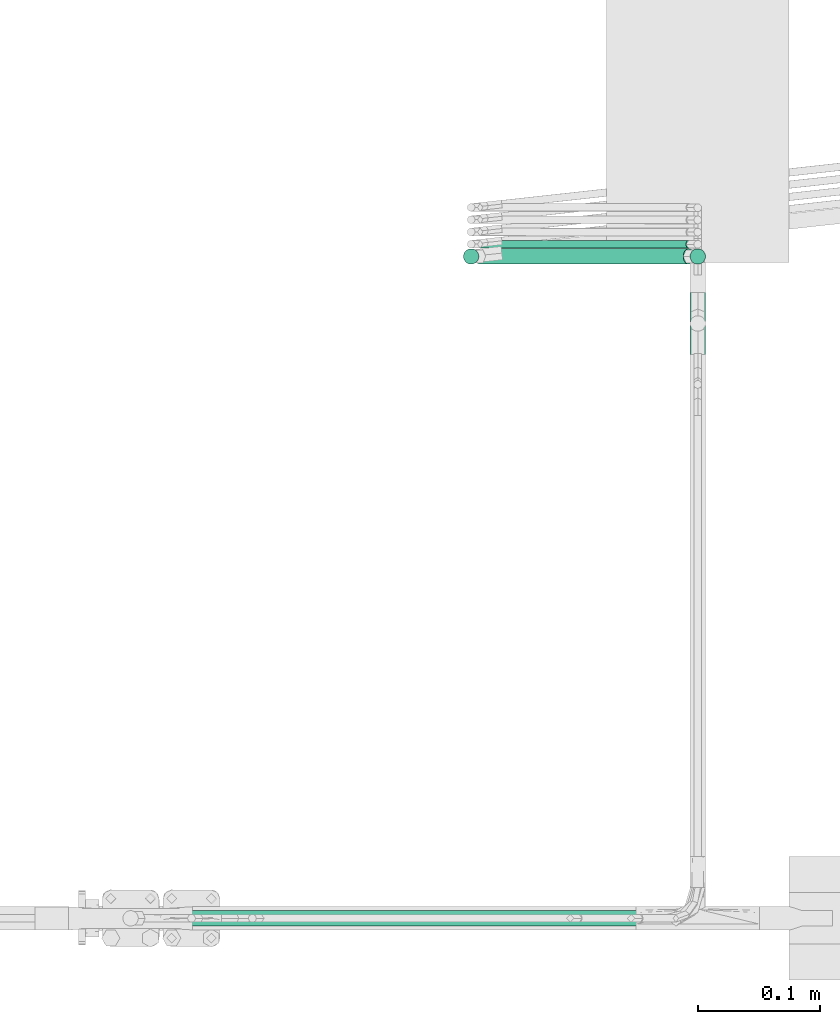
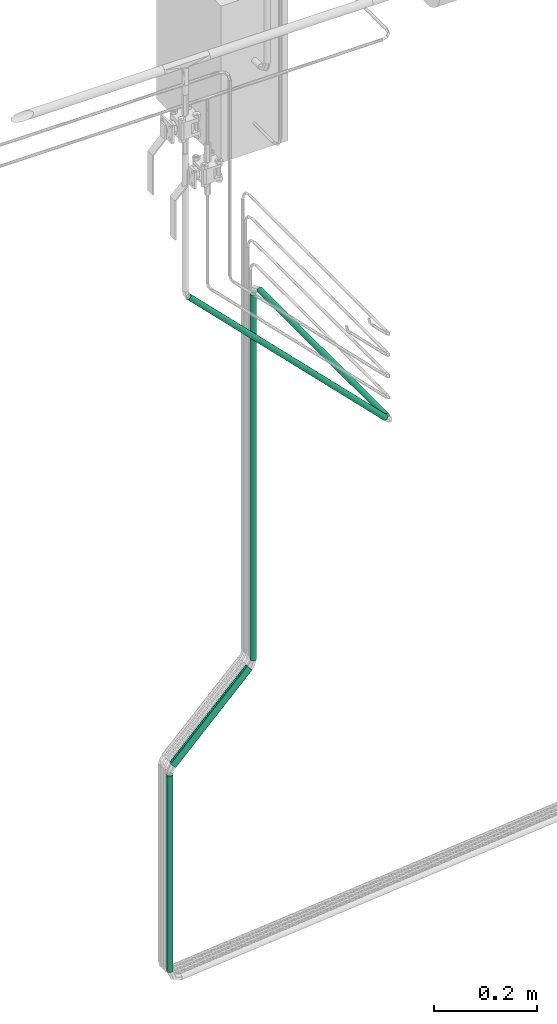
# One storey, part 10 of 45: 6 flow segments.
"""IFC2X3 building model written with IfcOpenShell, lengths in millimetres."""

from ifc_helpers import new_model, entity, si_unit, converted_unit, derived_unit, direction, frame, origin, origin_2d_with_axis, place, context, subcontext, project, spatial, circle, extrude, type_object, element, save


model = new_model("IFC2X3")

# Units and contexts
model_context = context("Model", 3, precision=0.01, world=origin(), true_north=direction((6.12303176911189e-17, 1.0)))
body_context = subcontext(model_context, "Body", "Model", "MODEL_VIEW")
ifc_project = project(units=[si_unit("LENGTHUNIT", "METRE", prefix="MILLI"), si_unit("AREAUNIT", "SQUARE_METRE"), si_unit("VOLUMEUNIT", "CUBIC_METRE"), converted_unit("PLANEANGLEUNIT", "DEGREE", entity("IfcRatioMeasure", 0.0174532925199433), si_unit("PLANEANGLEUNIT", "RADIAN"), dimensions=[0, 0, 0, 0, 0, 0, 0]), si_unit("MASSUNIT", "GRAM", prefix="KILO"), derived_unit("MASSDENSITYUNIT", [(si_unit("MASSUNIT", "GRAM", prefix="KILO"), 1), (si_unit("LENGTHUNIT", "METRE"), -3)]), derived_unit("MOMENTOFINERTIAUNIT", [(si_unit("LENGTHUNIT", "METRE"), 4)]), si_unit("TIMEUNIT", "SECOND"), si_unit("FREQUENCYUNIT", "HERTZ"), si_unit("THERMODYNAMICTEMPERATUREUNIT", "DEGREE_CELSIUS"), derived_unit("THERMALTRANSMITTANCEUNIT", [(si_unit("MASSUNIT", "GRAM", prefix="KILO"), 1), (si_unit("THERMODYNAMICTEMPERATUREUNIT", "KELVIN"), -1), (si_unit("TIMEUNIT", "SECOND"), -3)]), derived_unit("VOLUMETRICFLOWRATEUNIT", [(si_unit("LENGTHUNIT", "METRE"), 3), (si_unit("TIMEUNIT", "SECOND"), -1)]), derived_unit("MASSFLOWRATEUNIT", [(si_unit("MASSUNIT", "GRAM", prefix="KILO"), 1), (si_unit("TIMEUNIT", "SECOND"), -1)]), derived_unit("ROTATIONALFREQUENCYUNIT", [(si_unit("TIMEUNIT", "SECOND"), -1)]), si_unit("ELECTRICCURRENTUNIT", "AMPERE"), si_unit("ELECTRICVOLTAGEUNIT", "VOLT"), si_unit("POWERUNIT", "WATT"), si_unit("FORCEUNIT", "NEWTON", prefix="KILO"), si_unit("ILLUMINANCEUNIT", "LUX"), si_unit("LUMINOUSFLUXUNIT", "LUMEN"), si_unit("LUMINOUSINTENSITYUNIT", "CANDELA"), derived_unit("USERDEFINED", [(si_unit("MASSUNIT", "GRAM", prefix="KILO"), -1), (si_unit("LENGTHUNIT", "METRE"), -2), (si_unit("TIMEUNIT", "SECOND"), 3), (si_unit("LUMINOUSFLUXUNIT", "LUMEN"), 1)]), derived_unit("LINEARVELOCITYUNIT", [(si_unit("LENGTHUNIT", "METRE"), 1), (si_unit("TIMEUNIT", "SECOND"), -1)]), si_unit("PRESSUREUNIT", "PASCAL"), derived_unit("USERDEFINED", [(si_unit("LENGTHUNIT", "METRE"), -2), (si_unit("MASSUNIT", "GRAM", prefix="KILO"), 1), (si_unit("TIMEUNIT", "SECOND"), -2)]), derived_unit("LINEARFORCEUNIT", [(si_unit("MASSUNIT", "GRAM", prefix="KILO"), 1), (si_unit("LENGTHUNIT", "METRE"), 1), (si_unit("TIMEUNIT", "SECOND"), -2), (si_unit("LENGTHUNIT", "METRE"), -1)]), derived_unit("PLANARFORCEUNIT", [(si_unit("MASSUNIT", "GRAM", prefix="KILO"), 1), (si_unit("LENGTHUNIT", "METRE"), 1), (si_unit("TIMEUNIT", "SECOND"), -2), (si_unit("LENGTHUNIT", "METRE"), -2)])], contexts=[model_context])

# Site, building, storey
site_placement = place(None, frame((-24836.06, 8968.75, 0.0)))
site = spatial("IfcSite", under=ifc_project, at=site_placement, CompositionType="ELEMENT")
building_placement = place(site_placement, origin())
building = spatial("IfcBuilding", under=site, at=building_placement, CompositionType="ELEMENT")
storey_placement = place(building_placement, frame((0.0, 0.0, -4200.0)))
storey = spatial("IfcBuildingStorey", under=building, at=storey_placement, CompositionType="ELEMENT", Elevation=-4200.0)

# Flow segments
pipe_segment_type = type_object("IfcPipeSegmentType", PredefinedType="NOTDEFINED")
flow_segment_1_placement = place(storey_placement, frame((69456.91, -8401.84, -374.6)))
element("IfcFlowSegment", 1, at=flow_segment_1_placement, inside=storey, type_object=pipe_segment_type, context=body_context, shape_type="SweptSolid", body=[
    extrude(circle(Radius=6.35, at=origin_2d_with_axis()), frame((7.95, 7.95, 0.0)), (0.0, 0.0, 1.0), 464.078975515725),
])
flow_segment_2_placement = place(storey_placement, frame((69466.21, -8401.84, 101.35)))
element("IfcFlowSegment", 2, at=flow_segment_2_placement, inside=storey, type_object=pipe_segment_type, context=body_context, shape_type="SweptSolid", body=[
    extrude(circle(Radius=6.35, at=origin_2d_with_axis()), frame((6.09, 7.95, 6.09), z_axis=(0.707106781186545, 0.0, 0.70710678118655), x_axis=(0.0, -1.0, 0.0)), (0.0, 0.0, 1.0), 242.072765822238),
])
flow_segment_3_placement = place(storey_placement, frame((69642.96, -8401.84, 296.57)))
element("IfcFlowSegment", 3, at=flow_segment_3_placement, inside=storey, type_object=pipe_segment_type, context=body_context, shape_type="SweptSolid", body=[
    extrude(circle(Radius=6.35, at=origin_2d_with_axis()), frame((7.95, 7.95, 0.0), z_axis=(0.0, 0.0, 1.0), x_axis=(-1.0, 0.0, 0.0)), (0.0, 0.0, 1.0), 864.078975515725),
])
flow_segment_4_placement = place(storey_placement, frame((69642.96, -8911.84, 1178.1)))
element("IfcFlowSegment", 4, at=flow_segment_4_placement, inside=storey, type_object=pipe_segment_type, context=body_context, shape_type="SweptSolid", body=[
    extrude(circle(Radius=6.35, at=origin_2d_with_axis()), frame((7.95, 0.0, 7.95), z_axis=(0.0, 1.0, 0.0), x_axis=(-1.0, 0.0, 0.0)), (0.0, 0.0, 1.0), 492.548419713841),
])
flow_segment_5_placement = place(storey_placement, frame((69186.67, -8945.19, 1197.93)))
element("IfcFlowSegment", 5, at=flow_segment_5_placement, inside=storey, type_object=pipe_segment_type, context=body_context, shape_type="SweptSolid", body=[
    extrude(circle(Radius=6.35, at=origin_2d_with_axis()), frame((446.28, 7.95, 6.09), z_axis=(-0.707106781186541, 0.0, 0.707106781186554), x_axis=(0.0, 1.0, 0.0)), (0.0, 0.0, 1.0), 622.528181270807),
])
flow_segment_6_placement = place(storey_placement, frame((69468.46, -8388.67, 103.6)))
element("IfcFlowSegment", 6, at=flow_segment_6_placement, inside=storey, type_object=pipe_segment_type, context=body_context, shape_type="SweptSolid", body=[
    extrude(circle(Radius=3.175, at=origin_2d_with_axis()), frame((3.84, 4.83, 3.84), z_axis=(0.70710675914046, -0.000249711367439261, 0.707106759140449), x_axis=(0.000353145191501012, 0.999999937644235, 0.0)), (0.0, 0.0, 1.0), 242.072773392094),
])

save(model, "model.ifc")
